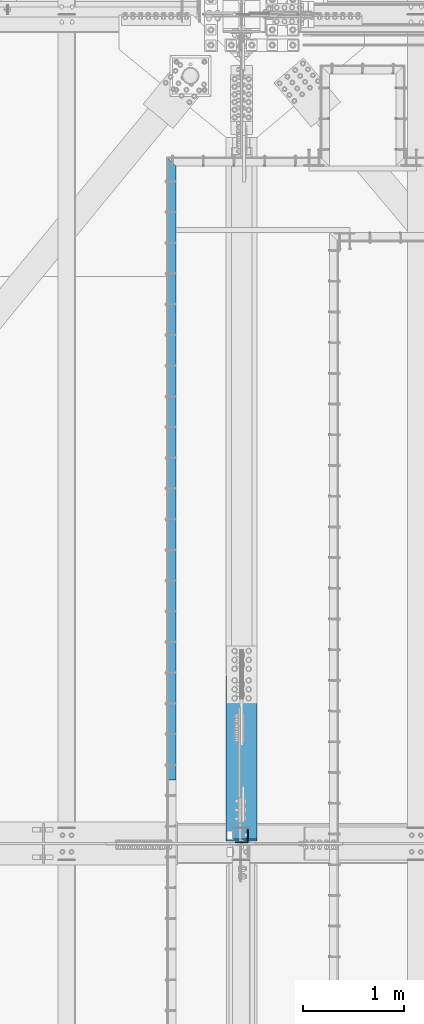
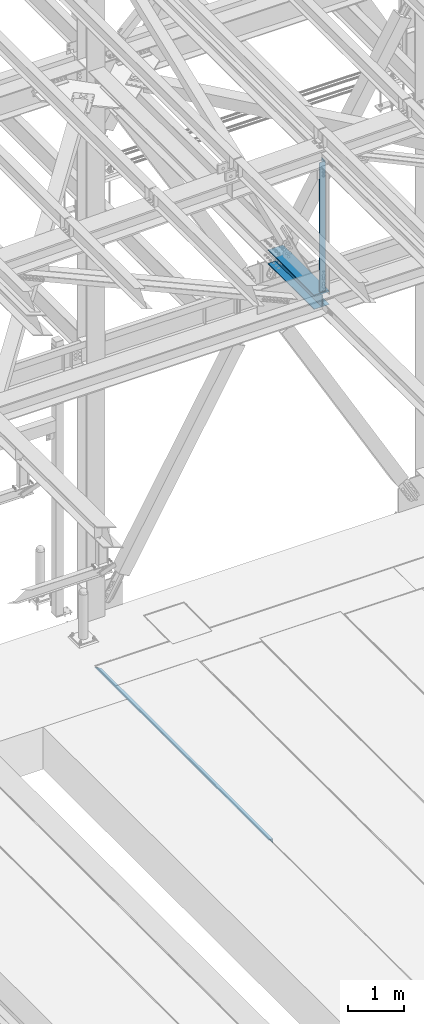
# One storey, part 1909 of 3843: 3 beams, 3 elements without a shape of their own.
"""IFC2X3 building model written with IfcOpenShell, lengths in millimetres."""

from ifc_helpers import new_model, si_unit, frame, origin_with_axes, place, context, subcontext, project, spatial, faceted_brep, material, type_object, element, aggregate, save


model = new_model("IFC2X3")

# Units and contexts
model_context = context("Model", 3, precision=1e-05, world=origin_with_axes())
body_context = subcontext(model_context, "Body", "Model", "MODEL_VIEW")
ifc_project = project(units=[si_unit("LENGTHUNIT", "METRE", prefix="MILLI"), si_unit("AREAUNIT", "SQUARE_METRE"), si_unit("VOLUMEUNIT", "CUBIC_METRE"), si_unit("MASSUNIT", "GRAM", prefix="KILO"), si_unit("TIMEUNIT", "SECOND"), si_unit("PLANEANGLEUNIT", "RADIAN"), si_unit("SOLIDANGLEUNIT", "STERADIAN"), si_unit("THERMODYNAMICTEMPERATUREUNIT", "DEGREE_CELSIUS"), si_unit("LUMINOUSINTENSITYUNIT", "LUMEN")], contexts=[model_context])

# Site, building, storey
site_placement = place(None, origin_with_axes())
site = spatial("IfcSite", under=ifc_project, at=site_placement, CompositionType="ELEMENT")
building_placement = place(site_placement, origin_with_axes())
building = spatial("IfcBuilding", under=site, at=building_placement, Name="Undefined", CompositionType="ELEMENT")
storey_placement = place(building_placement, origin_with_axes())
storey = spatial("IfcBuildingStorey", under=building, at=storey_placement, Name="Undefined", CompositionType="ELEMENT", Elevation=0.0)

# Assembly, beam
assembly_1_placement = place(storey_placement, origin_with_axes())
assembly_1 = element("IfcElementAssembly", 1, at=assembly_1_placement, inside=storey, Name="EMBED_ANGLE", AssemblyPlace="NOTDEFINED", PredefinedType="RIGID_FRAME")
ifc_material_1 = material(Name="STEEL/A36")
beam_type_1 = type_object("IfcBeamType", Name="L3-1/2X3-1/2X5/16", PredefinedType="NOTDEFINED")
beam_1_placement = place(assembly_1_placement, frame((48298.8616210938, 84613.6230224609, 30410.15), z_axis=(0.0, 0.0, -1.0), x_axis=(0.0, 1.0, 0.0)))
beam_1 = element("IfcBeam", 2, at=beam_1_placement, type_object=beam_type_1, material=ifc_material_1, Name="EMBED_ANGLE", ObjectType="L3-1/2X3-1/2X5/16", context=body_context, shape_type="Brep", body=[
    faceted_brep([(-3.63797880709171e-12, 44.4499999999971, -44.4500000000007), (-3.63797880709171e-12, 44.4499999999971, 44.4500000000007), (6096.0, 44.4499999999971, 44.4500000000007), (6096.0, 44.4499999999971, -44.4500000000007), (-3.63797880709171e-12, 36.5124999999971, 44.4500000000007), (6103.9375, 36.5124999999971, 44.4500000000007), (-3.63797880709171e-12, 36.5124999999971, -36.5125000000007), (6103.9375, 36.5124999999971, -36.5125000000007), (3.63797880709171e-12, -44.4499999999971, -36.5125000000007), (6184.89999999999, -44.4499999999971, -36.5125000000007), (3.63797880709171e-12, -44.4499999999971, -44.4500000000007), (6184.89999999999, -44.4499999999971, -44.4500000000007)], [[[0, 1, 2, 3]], [[1, 4, 5, 2]], [[4, 6, 7, 5]], [[6, 8, 9, 7]], [[8, 10, 11, 9]], [[10, 0, 3, 11]], [[5, 7, 9, 11, 3, 2]], [[10, 8, 6, 4, 1, 0]]]),
])
aggregate(assembly_1, [beam_1])

assembly_2_placement = place(storey_placement, origin_with_axes())
assembly_2 = element("IfcElementAssembly", 3, at=assembly_2_placement, inside=storey, Name="BEAM", AssemblyPlace="NOTDEFINED", PredefinedType="RIGID_FRAME")
ifc_material_2 = material(Name="STEEL/A992")
beam_type_2 = type_object("IfcBeamType", Name="W12X79", PredefinedType="NOTDEFINED")
beam_2_placement = place(assembly_2_placement, frame((48996.6, 83985.1000000144, 42252.5468485859), z_axis=(0.0, 0.00072869199964043, 0.99999973450395), x_axis=(0.0, 0.99999973450395, -0.000728691999638273)))
beam_2 = element("IfcBeam", 4, at=beam_2_placement, type_object=beam_type_2, material=ifc_material_2, Name="BEAM", ObjectType="W12X79", context=body_context, shape_type="Brep", body=[
    faceted_brep([(19.7292268722958, 6.34999999999854, -131.762500001227), (7.02922687234241, -6.34999999999854, -119.062500001353), (7.02922687247337, -6.34999999999854, 119.062500001382), (19.7292268724414, 6.34999999999854, 131.7625000021), (26.0792268716323, 6.34999999999854, -138.112500000534), (26.0792268716323, 153.987500000003, -138.112500000534), (45.1292268718971, 153.987500000003, -157.162500000624), (45.1292268718971, -153.987500000003, -157.162500001818), (26.0792268716323, -153.987500000003, -138.112500000534), (26.0792268716323, -6.34999999999854, -138.112500000534), (1670.05044506729, -153.987500000003, 138.112499998482), (1670.05044506729, -153.987500000003, 157.162499998551), (45.1292268718971, -153.987500000003, 157.162500001752), (26.079226870439, -153.987500000003, 138.112500000476), (1670.05044506729, 153.987500000003, 157.162499998551), (45.1292268718971, 153.987500000003, 157.162500000515), (1670.05044506729, 153.987500000003, 138.112499998482), (26.079226870439, 153.987500000003, 138.112500000476), (1670.05044506729, 6.34999999999854, 138.112499998482), (26.079226870439, 6.34999999999854, 138.112500000476), (26.079226870439, -6.34999999999854, 138.112500000476), (1670.05044506729, -6.34999999999854, 138.112499998482), (1670.0504450673, 6.34999999999854, -138.11250000252), (1670.0504450673, -6.34999999999854, -138.11250000252), (1670.0504450673, -153.987500000003, -138.11250000252), (1670.0504450673, -153.987500000003, -157.162500002589), (1670.0504450673, 153.987500000003, -157.162500002589), (1670.0504450673, 153.987500000003, -138.11250000252)], [[[0, 1, 2, 3]], [[4, 5, 6, 7, 8, 9, 1, 0]], [[10, 11, 12, 13]], [[11, 14, 15, 12]], [[14, 16, 17, 15]], [[16, 18, 19, 17]], [[20, 13, 12, 15, 17, 19, 3, 2]], [[21, 10, 13, 20]], [[22, 18, 16, 14, 11, 10, 21, 23, 24, 25, 26, 27]], [[26, 25, 7, 6]], [[27, 26, 6, 5]], [[22, 27, 5, 4]], [[19, 18, 22, 4, 0, 3]], [[23, 21, 20, 2, 1, 9]], [[24, 23, 9, 8]], [[25, 24, 8, 7]]]),
])
aggregate(assembly_2, [beam_2])

assembly_3_placement = place(storey_placement, origin_with_axes())
assembly_3 = element("IfcElementAssembly", 5, at=assembly_3_placement, inside=storey, Name="ANGLE", AssemblyPlace="NOTDEFINED", PredefinedType="RIGID_FRAME")
ifc_material_3 = material(Name="STEEL/A572-50")
beam_type_3 = type_object("IfcBeamType", Name="L5X5X3/8", PredefinedType="NOTDEFINED")
beam_3_placement = place(assembly_3_placement, frame((48996.6, 84058.125, 45490.2521635), z_axis=(-1.0, 0.0, 0.0), x_axis=(0.0, 0.0, -1.0)))
beam_3 = element("IfcBeam", 6, at=beam_3_placement, type_object=beam_type_3, material=ifc_material_3, Name="ANGLE", ObjectType="L5X5X3/8", context=body_context, shape_type="Brep", body=[
    faceted_brep([(222.944092577207, 63.5, -63.5), (222.944092577207, 63.5, 63.5), (3028.46985177801, 63.5, 63.5), (3028.46985177801, 63.5, -63.5), (222.944092577207, 53.9750000000058, 63.5), (3028.46985177801, 53.9750000000058, 63.5), (222.944092577207, 53.9750000000058, -53.9749999999985), (3028.46985177801, 53.9750000000058, -53.9749999999985), (222.944092577207, -63.5, -53.9749999999985), (3028.46985177801, -63.5, -53.9749999999985), (222.944092577207, -63.5, -63.5), (3028.46985177801, -63.5, -63.5)], [[[0, 1, 2, 3]], [[1, 4, 5, 2]], [[4, 6, 7, 5]], [[6, 8, 9, 7]], [[8, 10, 11, 9]], [[10, 0, 3, 11]], [[5, 7, 9, 11, 3, 2]], [[10, 8, 6, 4, 1, 0]]]),
])
aggregate(assembly_3, [beam_3])

save(model, "model.ifc")
